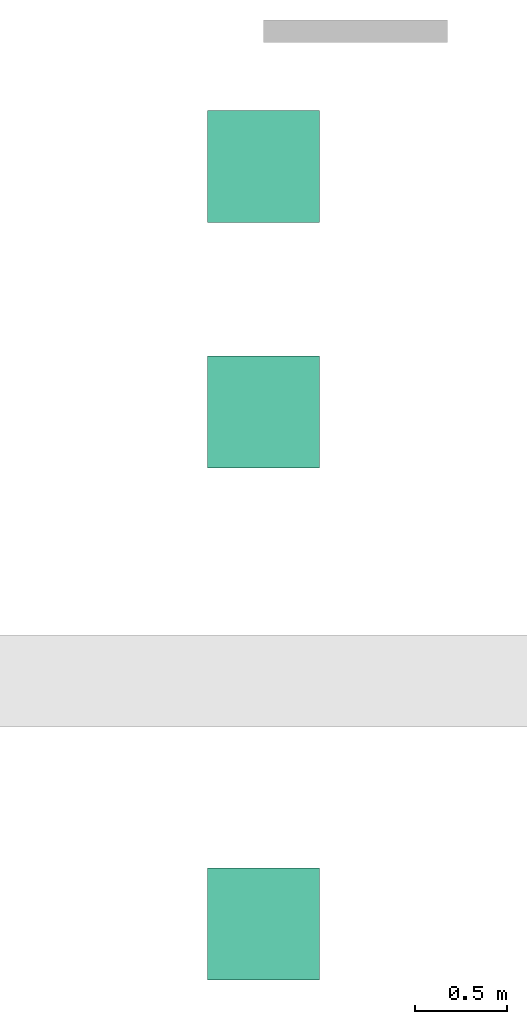
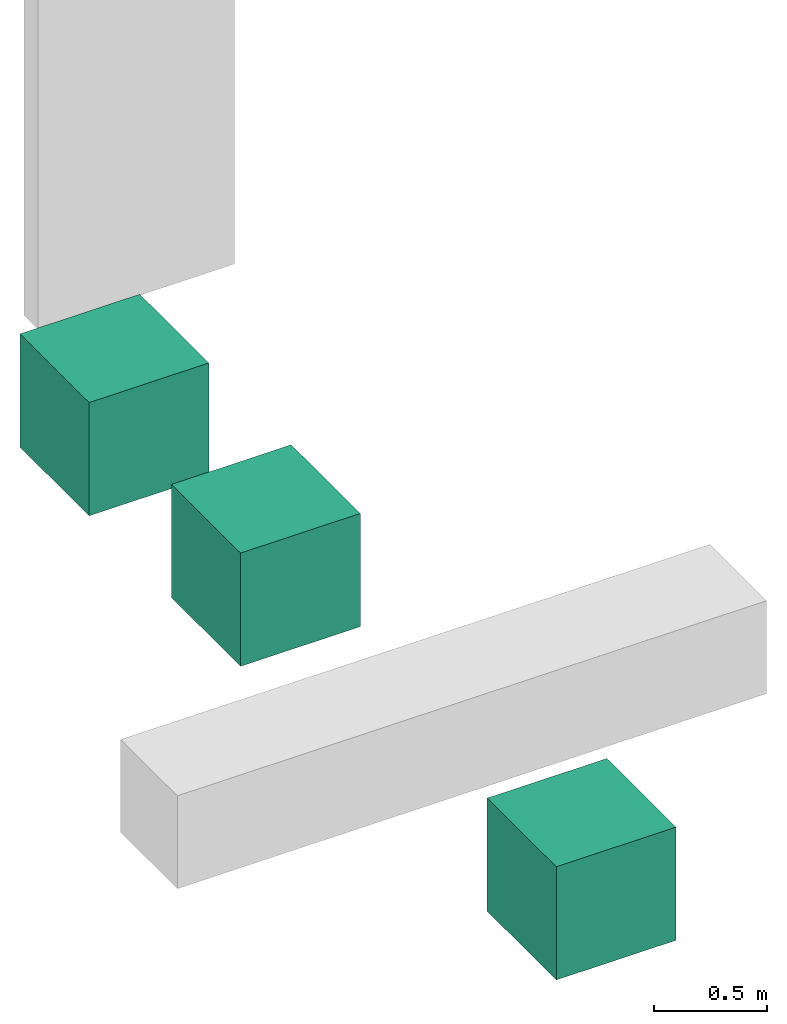
# One storey, part 2 of 2: 3 actuators.
"""IFC4 building model written with IfcOpenShell, lengths in feet."""

from ifc_helpers import new_model, entity, si_unit, converted_unit, frame, origin_with_axes, origin_2d_with_axis, place, context, subcontext, project, spatial, polygons, material, material_list, constituent, constituent_set, element, save


model = new_model("IFC4")

# Units and contexts
model_context = context("Model", 3, precision=1e-05, world=origin_with_axes())
plan_context = context("Plan", 2, precision=1e-05, world=origin_2d_with_axis())
body_context = subcontext(model_context, "Body", "Model", "MODEL_VIEW")
ifc_project = project(units=[converted_unit("AREAUNIT", "square foot", entity("IfcReal", 0.09290304), si_unit("AREAUNIT", "SQUARE_METRE"), dimensions=[2, 0, 0, 0, 0, 0, 0]), converted_unit("LENGTHUNIT", "foot", entity("IfcReal", 0.3048), si_unit("LENGTHUNIT", "METRE"), dimensions=[1, 0, 0, 0, 0, 0, 0]), converted_unit("VOLUMEUNIT", "cubic foot", entity("IfcReal", 0.0283168467116885), si_unit("VOLUMEUNIT", "CUBIC_METRE"), dimensions=[3, 0, 0, 0, 0, 0, 0]), converted_unit("PLANEANGLEUNIT", "degree", entity("IfcReal", 0.0174532925199433), si_unit("PLANEANGLEUNIT", "RADIAN"), dimensions=[0, 0, 0, 0, 0, 0, 0])], contexts=[model_context, plan_context])

# Site, building, storey
site_placement = place(None, origin_with_axes())
site = spatial("IfcSite", under=ifc_project, at=site_placement)
building_placement = place(site_placement, origin_with_axes())
building = spatial("IfcBuilding", under=site, at=building_placement, Name="Building")
storey_placement = place(building_placement, origin_with_axes())
storey = spatial("IfcBuildingStorey", under=building, at=storey_placement, Name="Storey")

# Actuators
ifc_material_1 = material(Name="1_Material")
actuator_1_placement = place(storey_placement, frame((0.0, -2.21344859894179, 0.0), z_axis=(0.0, 0.0, 1.0), x_axis=(1.0, 0.0, 0.0)))
element("IfcActuator", 1, at=actuator_1_placement, inside=storey, material=ifc_material_1, Name="Cube", PredefinedType="ELECTRICACTUATOR", context=body_context, shape_type="Tessellation", body=[
    polygons([(-1.0, -1.0, -1.0), (-1.0, -1.0, 1.0), (-1.0, 1.0, -1.0), (-1.0, 1.0, 1.0), (1.0, -1.0, -1.0), (1.0, -1.0, 1.0), (1.0, 1.0, -1.0), (1.0, 1.0, 1.0)], [[[1, 2, 4, 3]], [[3, 4, 8, 7]], [[7, 8, 6, 5]], [[5, 6, 2, 1]], [[3, 7, 5, 1]], [[8, 4, 2, 6]]], closed=True),
])
ifc_constituent_1 = constituent(ifc_material_1)
ifc_material_2 = material(Name="2_Material")
ifc_constituent_2 = constituent(ifc_material_2)
ifc_constituent_set = constituent_set(constituents=[ifc_constituent_1, ifc_constituent_2])
actuator_2_placement = place(storey_placement, frame((0.0, -6.59617773816967, 0.0), z_axis=(0.0, 0.0, 1.0), x_axis=(1.0, 0.0, 0.0)))
element("IfcActuator", 2, at=actuator_2_placement, inside=storey, material=ifc_constituent_set, Name="Cube", PredefinedType="ELECTRICACTUATOR", context=body_context, shape_type="Tessellation", body=[
    polygons([(-1.0, -1.0, -1.0), (-1.0, -1.0, 1.0), (-1.0, 1.0, -1.0), (-1.0, 1.0, 1.0), (1.0, -1.0, -1.0), (1.0, -1.0, 1.0), (1.0, 1.0, -1.0), (1.0, 1.0, 1.0)], [[[1, 2, 4, 3]], [[3, 4, 8, 7]], [[7, 8, 6, 5]], [[5, 6, 2, 1]], [[3, 7, 5, 1]], [[8, 4, 2, 6]]], closed=True),
])
ifc_material_list = material_list([ifc_material_1, ifc_material_2])
actuator_3_placement = place(storey_placement, frame((0.0, -15.7318058915026, 0.0), z_axis=(0.0, 0.0, 1.0), x_axis=(1.0, 0.0, 0.0)))
element("IfcActuator", 3, at=actuator_3_placement, inside=storey, material=ifc_material_list, Name="Cube", PredefinedType="ELECTRICACTUATOR", context=body_context, shape_type="Tessellation", body=[
    polygons([(-1.0, -1.0, -1.0), (-1.0, -1.0, 1.0), (-1.0, 1.0, -1.0), (-1.0, 1.0, 1.0), (1.0, -1.0, -1.0), (1.0, -1.0, 1.0), (1.0, 1.0, -1.0), (1.0, 1.0, 1.0)], [[[1, 2, 4, 3]], [[3, 4, 8, 7]], [[7, 8, 6, 5]], [[5, 6, 2, 1]], [[3, 7, 5, 1]], [[8, 4, 2, 6]]], closed=True),
])

save(model, "model.ifc")
